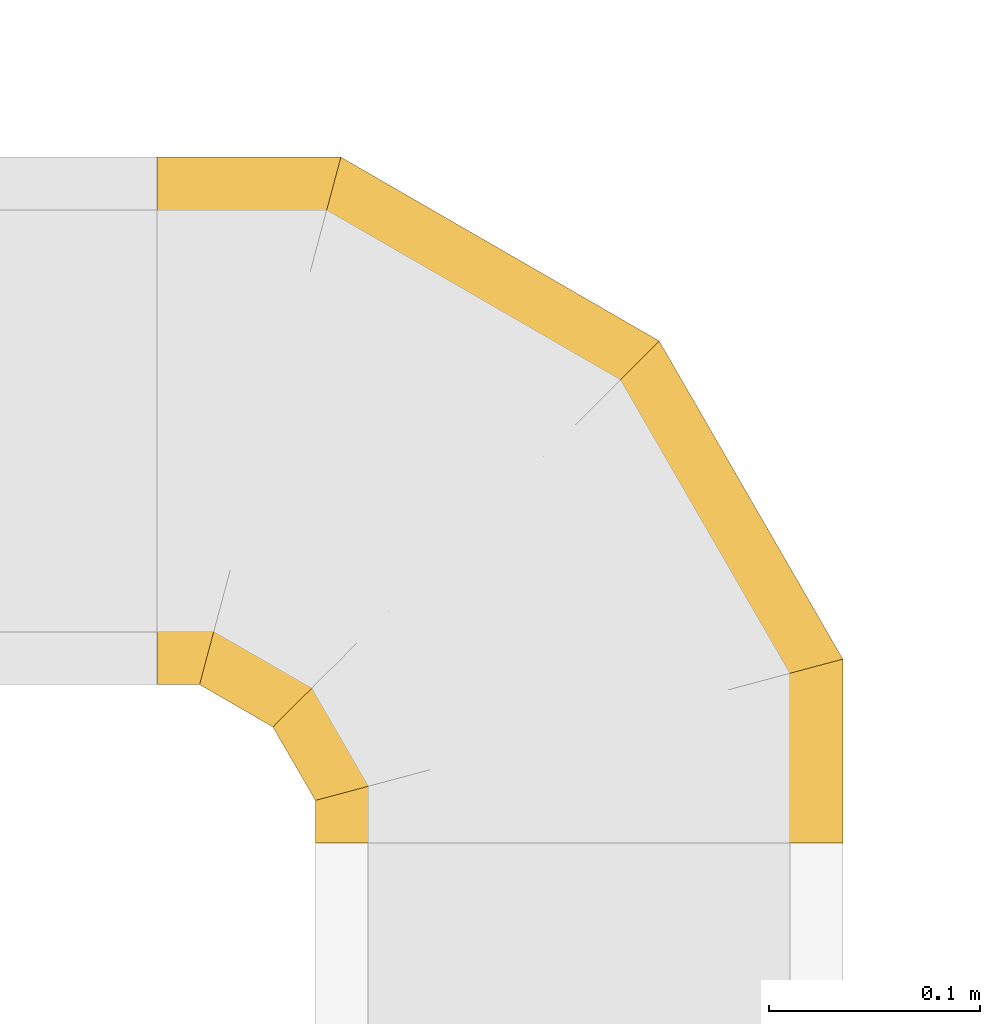
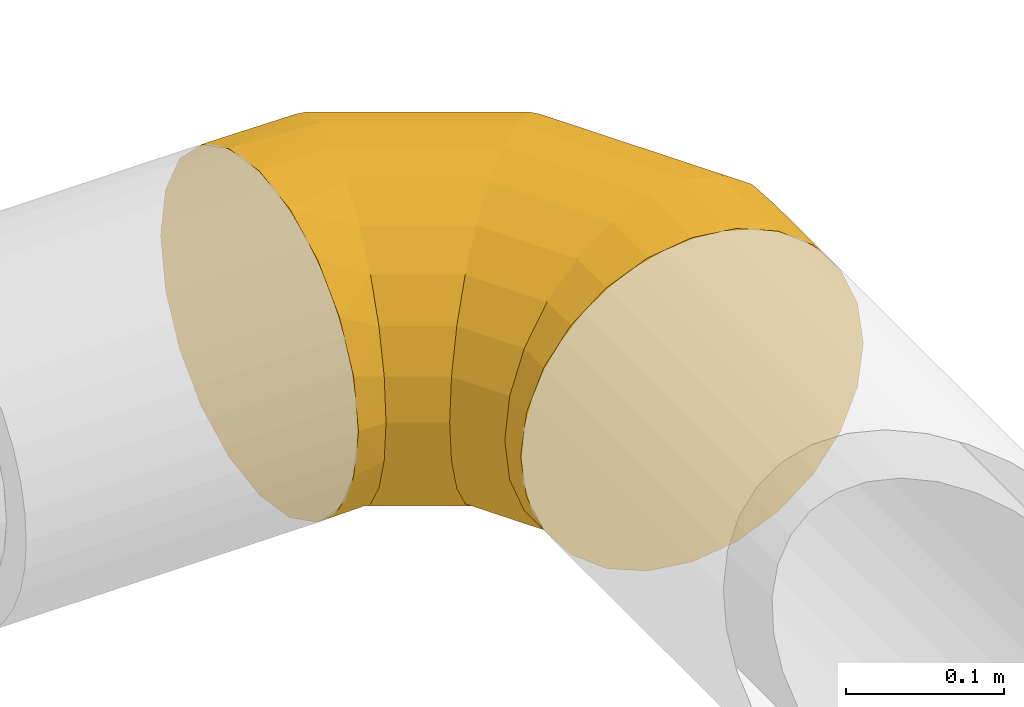
# One storey, part 29 of 92: 1 covering.
"""IFC2X3 building model written with IfcOpenShell, lengths in millimetres."""

from ifc_helpers import new_model, entity, si_unit, converted_unit, derived_unit, direction, frame, origin, place, context, subcontext, project, spatial, faceted_brep, element, save


model = new_model("IFC2X3")

# Units and contexts
model_context = context("Model", 3, precision=0.01, world=origin(), true_north=direction((6.12303176911189e-17, 1.0)))
body_context = subcontext(model_context, "Body", "Model", "MODEL_VIEW")
ifc_project = project(units=[si_unit("LENGTHUNIT", "METRE", prefix="MILLI"), si_unit("AREAUNIT", "SQUARE_METRE"), si_unit("VOLUMEUNIT", "CUBIC_METRE"), converted_unit("PLANEANGLEUNIT", "DEGREE", entity("IfcRatioMeasure", 0.0174532925199433), si_unit("PLANEANGLEUNIT", "RADIAN"), dimensions=[0, 0, 0, 0, 0, 0, 0]), si_unit("MASSUNIT", "GRAM", prefix="KILO"), derived_unit("MASSDENSITYUNIT", [(si_unit("MASSUNIT", "GRAM", prefix="KILO"), 1), (si_unit("LENGTHUNIT", "METRE"), -3)]), derived_unit("MOMENTOFINERTIAUNIT", [(si_unit("LENGTHUNIT", "METRE"), 4)]), si_unit("TIMEUNIT", "SECOND"), si_unit("FREQUENCYUNIT", "HERTZ"), si_unit("THERMODYNAMICTEMPERATUREUNIT", "DEGREE_CELSIUS"), derived_unit("THERMALTRANSMITTANCEUNIT", [(si_unit("MASSUNIT", "GRAM", prefix="KILO"), 1), (si_unit("THERMODYNAMICTEMPERATUREUNIT", "KELVIN"), -1), (si_unit("TIMEUNIT", "SECOND"), -3)]), derived_unit("VOLUMETRICFLOWRATEUNIT", [(si_unit("LENGTHUNIT", "METRE"), 3), (si_unit("TIMEUNIT", "SECOND"), -1)]), derived_unit("MASSFLOWRATEUNIT", [(si_unit("MASSUNIT", "GRAM", prefix="KILO"), 1), (si_unit("TIMEUNIT", "SECOND"), -1)]), derived_unit("ROTATIONALFREQUENCYUNIT", [(si_unit("TIMEUNIT", "SECOND"), -1)]), si_unit("ELECTRICCURRENTUNIT", "AMPERE"), si_unit("ELECTRICVOLTAGEUNIT", "VOLT"), si_unit("POWERUNIT", "WATT"), si_unit("FORCEUNIT", "NEWTON", prefix="KILO"), si_unit("ILLUMINANCEUNIT", "LUX"), si_unit("LUMINOUSFLUXUNIT", "LUMEN"), si_unit("LUMINOUSINTENSITYUNIT", "CANDELA"), derived_unit("USERDEFINED", [(si_unit("MASSUNIT", "GRAM", prefix="KILO"), -1), (si_unit("LENGTHUNIT", "METRE"), -2), (si_unit("TIMEUNIT", "SECOND"), 3), (si_unit("LUMINOUSFLUXUNIT", "LUMEN"), 1)]), derived_unit("LINEARVELOCITYUNIT", [(si_unit("LENGTHUNIT", "METRE"), 1), (si_unit("TIMEUNIT", "SECOND"), -1)]), si_unit("PRESSUREUNIT", "PASCAL"), derived_unit("USERDEFINED", [(si_unit("LENGTHUNIT", "METRE"), -2), (si_unit("MASSUNIT", "GRAM", prefix="KILO"), 1), (si_unit("TIMEUNIT", "SECOND"), -2)]), derived_unit("LINEARFORCEUNIT", [(si_unit("MASSUNIT", "GRAM", prefix="KILO"), 1), (si_unit("LENGTHUNIT", "METRE"), 1), (si_unit("TIMEUNIT", "SECOND"), -2), (si_unit("LENGTHUNIT", "METRE"), -1)]), derived_unit("PLANARFORCEUNIT", [(si_unit("MASSUNIT", "GRAM", prefix="KILO"), 1), (si_unit("LENGTHUNIT", "METRE"), 1), (si_unit("TIMEUNIT", "SECOND"), -2), (si_unit("LENGTHUNIT", "METRE"), -2)])], contexts=[model_context])

# Site, building, storey
site_placement = place(None, origin())
site = spatial("IfcSite", under=ifc_project, at=site_placement, CompositionType="ELEMENT")
building_placement = place(site_placement, origin())
building = spatial("IfcBuilding", under=site, at=building_placement, CompositionType="ELEMENT")
storey_placement = place(building_placement, frame((0.0, 0.0, 4200.0)))
storey = spatial("IfcBuildingStorey", under=building, at=storey_placement, CompositionType="ELEMENT", Elevation=4200.0)

# Covering
covering_placement = place(storey_placement, frame((71257.65, 13890.11, 3173.4)))
element("IfcCovering", 1, at=covering_placement, inside=storey, PredefinedType="INSULATION", context=body_context, shape_type="Brep", body=[
    faceted_brep([(0.0, 200.0, 251.6), (0.0, 238.63, 245.48), (0.0, 273.47, 227.72), (0.0, 301.13, 200.07), (0.0, 318.88, 165.22), (0.0, 325.0, 126.6), (0.0, 318.88, 87.97), (0.0, 301.13, 53.12), (0.0, 273.47, 25.47), (0.0, 238.63, 7.71), (0.0, 200.0, 1.6), (0.0, 161.37, 7.71), (0.0, 126.53, 25.47), (0.0, 98.87, 53.12), (0.0, 81.12, 87.97), (0.0, 75.0, 126.6), (0.0, 81.12, 165.22), (0.0, 98.87, 200.07), (0.0, 126.53, 227.72), (0.0, 161.37, 245.48), (308.25, 0.0, 64.1), (320.74, 0.0, 94.24), (325.0, 0.0, 126.6), (320.74, 0.0, 158.95), (308.25, 0.0, 189.1), (288.39, 0.0, 214.98), (262.5, 0.0, 234.85), (232.35, 0.0, 247.34), (200.0, 0.0, 251.6), (167.65, 0.0, 247.34), (137.5, 0.0, 234.85), (111.61, 0.0, 214.98), (91.75, 0.0, 189.1), (79.26, 0.0, 158.95), (75.0, 0.0, 126.6), (79.26, 0.0, 94.24), (91.75, 0.0, 64.1), (111.61, 0.0, 38.21), (137.5, 0.0, 18.34), (167.65, 0.0, 5.85), (200.0, 0.0, 1.6), (232.35, 0.0, 5.85), (262.5, 0.0, 18.34), (288.39, 0.0, 38.21), (325.0, 87.08, 126.6), (320.74, 85.94, 158.95), (308.25, 82.6, 189.1), (288.39, 77.27, 214.98), (262.5, 70.34, 234.85), (232.35, 62.26, 247.34), (200.0, 53.59, 251.6), (167.65, 44.92, 247.34), (137.5, 36.84, 234.85), (111.61, 29.91, 214.98), (91.75, 24.58, 189.1), (79.26, 21.24, 158.95), (75.0, 20.1, 126.6), (79.26, 21.24, 94.24), (91.75, 24.58, 64.1), (111.61, 29.91, 38.21), (167.65, 44.92, 5.85), (200.0, 53.59, 1.6), (137.5, 36.84, 18.34), (232.35, 62.26, 5.85), (262.5, 70.34, 18.34), (288.39, 77.27, 38.21), (308.25, 82.6, 64.1), (320.74, 85.94, 94.24), (237.92, 237.92, 126.6), (234.8, 234.8, 158.95), (225.66, 225.66, 189.1), (211.11, 211.11, 214.98), (192.16, 192.16, 234.85), (170.09, 170.09, 247.34), (146.41, 146.41, 251.6), (122.73, 122.73, 247.34), (100.66, 100.66, 234.85), (81.71, 81.71, 214.98), (67.16, 67.16, 189.1), (58.02, 58.02, 158.95), (54.9, 54.9, 126.6), (58.02, 58.02, 94.24), (67.16, 67.16, 64.1), (81.71, 81.71, 38.21), (122.73, 122.73, 5.85), (146.41, 146.41, 1.6), (100.66, 100.66, 18.34), (170.09, 170.09, 5.85), (192.16, 192.16, 18.34), (211.11, 211.11, 38.21), (225.66, 225.66, 64.1), (234.8, 234.8, 94.24), (87.08, 325.0, 126.6), (85.94, 320.74, 158.95), (82.6, 308.25, 189.1), (77.27, 288.39, 214.98), (70.34, 262.5, 234.85), (62.26, 232.35, 247.34), (53.59, 200.0, 251.6), (44.92, 167.65, 247.34), (36.84, 137.5, 234.85), (29.91, 111.61, 214.98), (24.58, 91.75, 189.1), (21.24, 79.26, 158.95), (20.1, 75.0, 126.6), (21.24, 79.26, 94.24), (24.58, 91.75, 64.1), (29.91, 111.61, 38.21), (44.92, 167.65, 5.85), (53.59, 200.0, 1.6), (36.84, 137.5, 18.34), (62.26, 232.35, 5.85), (70.34, 262.5, 18.34), (77.27, 288.39, 38.21), (82.6, 308.25, 64.1), (85.94, 320.74, 94.24)], [[[0, 1, 2, 3, 4, 5, 6, 7, 8, 9, 10, 11, 12, 13, 14, 15, 16, 17, 18, 19]], [[20, 21, 22, 23, 24, 25, 26, 27, 28, 29, 30, 31, 32, 33, 34, 35, 36, 37, 38, 39, 40, 41, 42, 43]], [[22, 44, 45, 23]], [[23, 45, 46, 24]], [[47, 25, 24, 46]], [[25, 47, 48, 26]], [[26, 48, 49, 27]], [[50, 28, 27, 49]], [[51, 52, 30, 29]], [[50, 51, 29, 28]], [[53, 31, 30, 52]], [[54, 55, 33, 32]], [[54, 32, 31, 53]], [[56, 34, 33, 55]], [[57, 58, 36, 35]], [[56, 57, 35, 34]], [[37, 36, 58, 59]], [[60, 61, 40, 39]], [[62, 60, 39, 38]], [[59, 62, 38, 37]], [[41, 40, 61, 63]], [[42, 41, 63, 64]], [[64, 65, 43, 42]], [[21, 20, 66, 67]], [[22, 21, 67, 44]], [[65, 66, 20, 43]], [[45, 44, 68, 69]], [[46, 45, 69, 70]], [[70, 71, 47, 46]], [[48, 47, 71, 72]], [[49, 48, 72, 73]], [[50, 49, 73, 74]], [[75, 76, 52, 51]], [[74, 75, 51, 50]], [[53, 52, 76, 77]], [[78, 79, 55, 54]], [[77, 78, 54, 53]], [[56, 55, 79, 80]], [[81, 82, 58, 57]], [[80, 81, 57, 56]], [[59, 58, 82, 83]], [[84, 85, 61, 60]], [[86, 84, 60, 62]], [[83, 86, 62, 59]], [[63, 61, 85, 87]], [[64, 63, 87, 88]], [[65, 64, 88, 89]], [[67, 66, 90, 91]], [[44, 67, 91, 68]], [[89, 90, 66, 65]], [[69, 68, 92, 93]], [[70, 69, 93, 94]], [[94, 95, 71, 70]], [[72, 71, 95, 96]], [[73, 72, 96, 97]], [[74, 73, 97, 98]], [[99, 100, 76, 75]], [[98, 99, 75, 74]], [[77, 76, 100, 101]], [[102, 103, 79, 78]], [[101, 102, 78, 77]], [[80, 79, 103, 104]], [[105, 106, 82, 81]], [[104, 105, 81, 80]], [[83, 82, 106, 107]], [[108, 109, 85, 84]], [[110, 108, 84, 86]], [[107, 110, 86, 83]], [[87, 85, 109, 111]], [[88, 87, 111, 112]], [[89, 88, 112, 113]], [[91, 90, 114, 115]], [[68, 91, 115, 92]], [[113, 114, 90, 89]], [[93, 5, 4]], [[94, 4, 3]], [[5, 93, 92]], [[93, 4, 94]], [[3, 95, 94]], [[96, 2, 1]], [[97, 1, 0]], [[95, 2, 96]], [[96, 1, 97]], [[0, 98, 97]], [[2, 95, 3]], [[99, 0, 19]], [[100, 19, 18]], [[99, 98, 0]], [[100, 99, 19]], [[18, 101, 100]], [[16, 15, 103]], [[17, 16, 102]], [[102, 101, 17]], [[104, 103, 15]], [[102, 16, 103]], [[17, 101, 18]], [[105, 15, 14]], [[106, 14, 13]], [[105, 104, 15]], [[106, 105, 14]], [[13, 107, 106]], [[110, 12, 11]], [[108, 11, 10]], [[110, 107, 12]], [[109, 108, 10]], [[110, 11, 108]], [[12, 107, 13]], [[111, 10, 9]], [[112, 9, 8]], [[10, 111, 109]], [[111, 9, 112]], [[8, 113, 112]], [[114, 7, 6]], [[115, 6, 5]], [[113, 7, 114]], [[115, 114, 6]], [[92, 115, 5]], [[7, 113, 8]]]),
])

save(model, "model.ifc")
